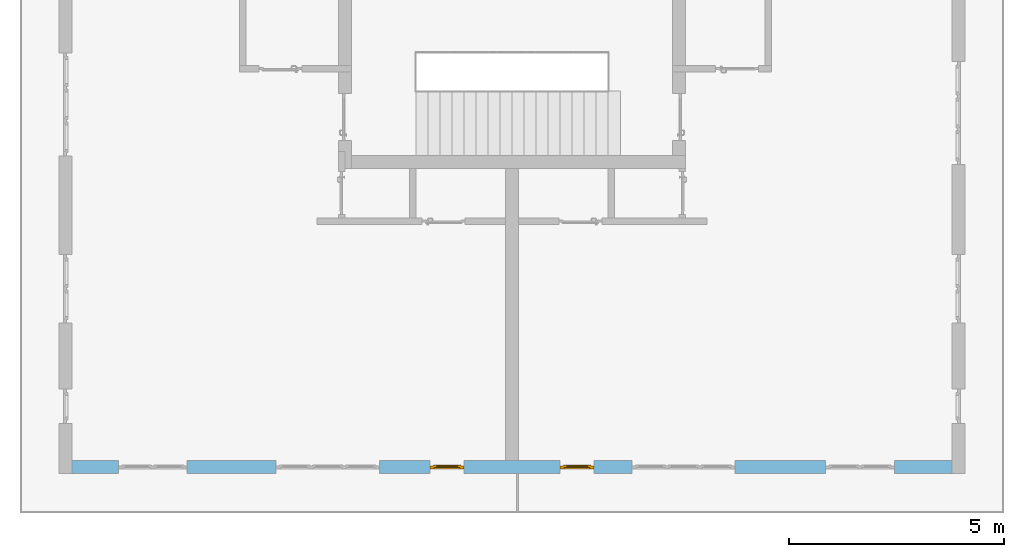
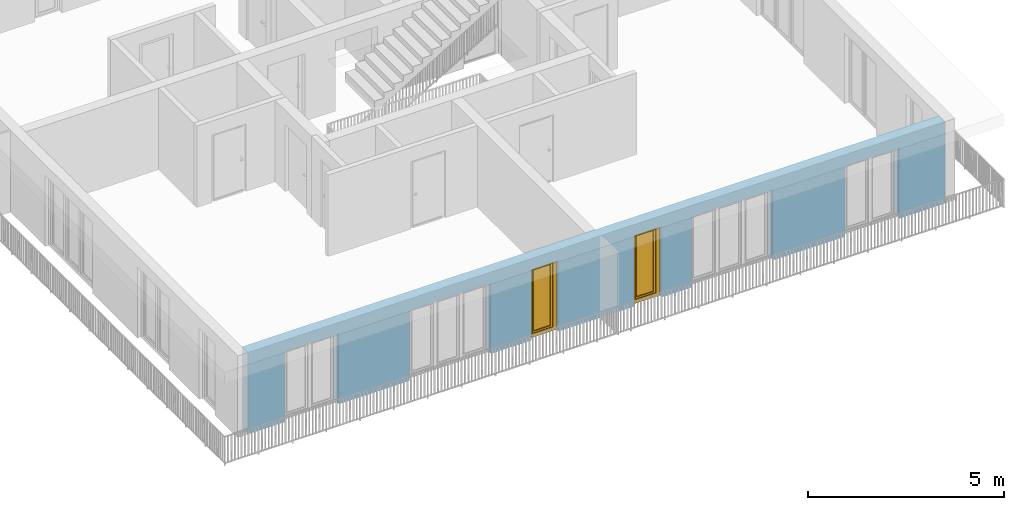
# One storey, part 6 of 48: 2 windows, 6 openings, plus 1 element that does not belong to this part.
"""IFC4 building model written with IfcOpenShell, lengths in metres."""

from ifc_helpers import new_model, entity, si_unit, converted_unit, derived_unit, direction, frame, origin_with_axes, place, context, subcontext, project, spatial, polygons, source, transform, mapped, material, type_object, element, fill, save


model = new_model("IFC4")

# Units and contexts
model_context = context("Model", 3, precision=1e-05, world=origin_with_axes(), true_north=direction((0.0, 1.0)))
body_context = subcontext(model_context, "Body", "Model", "MODEL_VIEW")
ifc_project = project(units=[si_unit("LENGTHUNIT", "METRE"), si_unit("AREAUNIT", "SQUARE_METRE"), si_unit("VOLUMEUNIT", "CUBIC_METRE"), converted_unit("PLANEANGLEUNIT", "DEGREE", entity("IfcPlaneAngleMeasure", 0.0174532925199), si_unit("PLANEANGLEUNIT", "RADIAN"), dimensions=[0, 0, 0, 0, 0, 0, 0]), converted_unit("TIMEUNIT", "Year", entity("IfcTimeMeasure", 31556926.0), si_unit("TIMEUNIT", "SECOND"), dimensions=[0, 0, 1, 0, 0, 0, 0]), si_unit("MASSUNIT", "GRAM", prefix="KILO"), si_unit("THERMODYNAMICTEMPERATUREUNIT", "DEGREE_CELSIUS"), si_unit("LUMINOUSINTENSITYUNIT", "LUMEN"), si_unit("ENERGYUNIT", "JOULE", prefix="MEGA"), derived_unit("THERMALCONDUCTANCEUNIT", [(si_unit("POWERUNIT", "WATT"), 1), (si_unit("LENGTHUNIT", "METRE"), -1), (si_unit("THERMODYNAMICTEMPERATUREUNIT", "KELVIN"), -1)]), derived_unit("SPECIFICHEATCAPACITYUNIT", [(si_unit("ENERGYUNIT", "JOULE"), 1), (si_unit("MASSUNIT", "GRAM", prefix="KILO"), -1), (si_unit("THERMODYNAMICTEMPERATUREUNIT", "KELVIN"), -1)]), derived_unit("MASSDENSITYUNIT", [(si_unit("MASSUNIT", "GRAM", prefix="KILO"), 1), (si_unit("VOLUMEUNIT", "CUBIC_METRE"), -1)])], contexts=[model_context])

# Site, building, storey
site_placement = place(None, origin_with_axes())
site = spatial("IfcSite", under=ifc_project, at=site_placement, CompositionType="ELEMENT")
building_placement = place(site_placement, origin_with_axes())
building = spatial("IfcBuilding", under=site, at=building_placement, CompositionType="ELEMENT")
storey_placement = place(building_placement, frame((0.0, 0.0, 3.4), z_axis=(0.0, 0.0, 1.0), x_axis=(1.0, 0.0, 0.0)))
storey = spatial("IfcBuildingStorey", under=building, at=storey_placement, Name="1. Geschoss", CompositionType="ELEMENT", Elevation=3.4)

# Wall, openings, windows
ifc_material = material()
wall_type = type_object("IfcWallType", Name="300", PredefinedType="NOTDEFINED")
wall_placement = place(storey_placement, frame((9.3378006196, -9.92881223104, 0.0), z_axis=(0.0, 0.0, 1.0), x_axis=(-1.0, 0.0, 0.0)))
wall = element("IfcWall", 1, at=wall_placement, inside=storey, type_object=wall_type, material=ifc_material, Name="Wand-001", PredefinedType="NOTDEFINED", context=body_context, shape_type="Tessellation", body=[
    polygons([(12.4515538751, -0.3, 2.2), (12.4515538751, -0.3, 0.0), (13.63, -0.3, 0.0), (13.63, -0.3, 2.2), (16.03, -0.3, 2.2), (16.03, -0.3, 0.0), (18.0998837323, -0.3, 0.0), (18.0998837323, -0.3, 2.2), (19.6998837323, -0.3, 2.2), (19.6998837323, -0.3, 0.0), (20.78, -0.3, 0.0), (20.78, -0.3, 2.54), (0.3, -0.3, 2.54), (0.3, -0.3, 0.0), (1.6378225413, -0.3, 0.0), (1.6378225413, -0.3, 2.2), (3.2378225413, -0.3, 2.2), (3.2378225413, -0.3, 0.0), (5.35, -0.3, 0.0), (5.35, -0.3, 2.2), (7.75, -0.3, 2.2), (7.75, -0.3, 0.0), (8.62617854928, -0.3, 0.0), (8.62617854928, -0.3, 2.2), (9.42617854928, -0.3, 2.2), (9.42617854928, -0.3, 0.0), (11.6515538751, -0.3, 0.0), (11.6515538751, -0.3, 2.2), (12.4515538751, -0.1, 0.0), (12.4515538751, 0.0, 2.2), (12.4515538751, 0.0, 0.0), (13.63, 0.0, 0.0), (13.63, 0.0, 2.2), (16.03, 0.0, 2.2), (16.03, 0.0, 0.0), (18.0998837323, 0.0, 0.0), (18.0998837323, 0.0, 2.2), (19.6998837323, 0.0, 2.2), (19.6998837323, 0.0, 0.0), (20.78, 0.0, 0.0), (20.78, 0.0, 2.54), (0.3, 0.0, 2.54), (0.3, 0.0, 0.0), (1.6378225413, 0.0, 0.0), (1.6378225413, 0.0, 2.2), (3.2378225413, 0.0, 2.2), (3.2378225413, 0.0, 0.0), (5.35, 0.0, 0.0), (5.35, 0.0, 2.2), (7.75, 0.0, 2.2), (7.75, 0.0, 0.0), (8.62617854928, 0.0, 0.0), (8.62617854928, 0.0, 2.2), (9.42617854928, 0.0, 2.2), (9.42617854928, 0.0, 0.0), (11.6515538751, -0.1, 0.0), (11.6515538751, 0.0, 0.0), (11.6515538751, 0.0, 2.2)], [[[1, 2, 3, 4, 5, 6, 7, 8, 9, 10, 11, 12, 13, 14, 15, 16, 17, 18, 19, 20, 21, 22, 23, 24, 25, 26, 27, 28]], [[29, 2, 1, 30, 31]], [[2, 29, 31, 32, 3]], [[32, 33, 4, 3]], [[33, 34, 5, 4]], [[34, 35, 6, 5]], [[36, 7, 6, 35]], [[36, 37, 8, 7]], [[37, 38, 9, 8]], [[38, 39, 10, 9]], [[40, 11, 10, 39]], [[40, 41, 12, 11]], [[41, 42, 13, 12]], [[14, 13, 42, 43]], [[15, 14, 43, 44]], [[16, 15, 44, 45]], [[17, 16, 45, 46]], [[18, 17, 46, 47]], [[19, 18, 47, 48]], [[20, 19, 48, 49]], [[21, 20, 49, 50]], [[22, 21, 50, 51]], [[51, 52, 23, 22]], [[52, 53, 24, 23]], [[53, 54, 25, 24]], [[54, 55, 26, 25]], [[56, 27, 26, 55, 57]], [[28, 27, 56, 57, 58]], [[1, 28, 58, 30]], [[32, 31, 30, 58, 57, 55, 54, 53, 52, 51, 50, 49, 48, 47, 46, 45, 44, 43, 42, 41, 40, 39, 38, 37, 36, 35, 34, 33]]], closed=True),
])
opening_1_placement = place(wall_placement, frame((18.8998837323, 0.0, 0.0), z_axis=(0.0, 0.0, 1.0), x_axis=(1.0, 0.0, 0.0)))
element("IfcOpeningElement", 2, at=opening_1_placement, cuts=wall, Name="Fenster-001", context=body_context, identifier="Reference", shape_type="Tessellation", body=[
    polygons([(-0.8, -0.1, 0.0), (-0.8, -0.1, 2.2), (-0.8, 0.001, 2.2), (-0.8, 0.001, 0.0), (-0.8, -0.301, 0.0), (-0.8, -0.301, 2.2), (0.8, -0.1, 2.2), (0.8, 0.001, 2.2), (0.8, -0.301, 2.2), (0.8, 0.001, 0.0), (0.8, -0.1, 0.0), (0.8, -0.301, 0.0)], [[[1, 2, 3, 4]], [[2, 1, 5, 6]], [[7, 8, 3, 2, 6, 9]], [[8, 10, 4, 3]], [[1, 4, 10, 11, 12, 5]], [[6, 5, 12, 9]], [[7, 11, 10, 8]], [[11, 7, 9, 12]]], closed=True),
])
opening_2_placement = place(wall_placement, frame((2.4378225413, 0.0, 0.0), z_axis=(0.0, 0.0, 1.0), x_axis=(1.0, 0.0, 0.0)))
element("IfcOpeningElement", 3, at=opening_2_placement, cuts=wall, Name="Fenster-002", context=body_context, identifier="Reference", shape_type="Tessellation", body=[
    polygons([(-0.8, -0.1, 0.0), (-0.8, -0.1, 2.2), (-0.8, 0.000999999999999, 2.2), (-0.8, 0.000999999999999, 0.0), (-0.8, -0.301, 0.0), (-0.8, -0.301, 2.2), (0.8, -0.1, 2.2), (0.8, 0.000999999999999, 2.2), (0.8, -0.301, 2.2), (0.8, 0.000999999999999, 0.0), (0.8, -0.1, 0.0), (0.8, -0.301, 0.0)], [[[1, 2, 3, 4]], [[2, 1, 5, 6]], [[7, 8, 3, 2, 6, 9]], [[8, 10, 4, 3]], [[1, 4, 10, 11, 12, 5]], [[6, 5, 12, 9]], [[7, 11, 10, 8]], [[11, 7, 9, 12]]], closed=True),
])
opening_3_placement = place(wall_placement, frame((14.83, 0.0, 0.0), z_axis=(0.0, 0.0, 1.0), x_axis=(1.0, 0.0, 0.0)))
element("IfcOpeningElement", 4, at=opening_3_placement, cuts=wall, Name="Fenster-002", context=body_context, identifier="Reference", shape_type="Tessellation", body=[
    polygons([(-1.2, -0.1, 0.0), (-1.2, -0.1, 2.2), (-1.2, 0.001, 2.2), (-1.2, 0.001, 0.0), (-1.2, -0.301, 0.0), (-1.2, -0.301, 2.2), (1.2, -0.1, 2.2), (1.2, 0.001, 2.2), (1.2, -0.301, 2.2), (1.2, 0.001, 0.0), (1.2, -0.1, 0.0), (1.2, -0.301, 0.0)], [[[1, 2, 3, 4]], [[2, 1, 5, 6]], [[7, 8, 3, 2, 6, 9]], [[8, 10, 4, 3]], [[1, 4, 10, 11, 12, 5]], [[6, 5, 12, 9]], [[7, 11, 10, 8]], [[11, 7, 9, 12]]], closed=True),
])
opening_4_placement = place(wall_placement, frame((6.55, 0.0, 0.0), z_axis=(0.0, 0.0, 1.0), x_axis=(1.0, 0.0, 0.0)))
element("IfcOpeningElement", 5, at=opening_4_placement, cuts=wall, Name="Fenster-003", context=body_context, identifier="Reference", shape_type="Tessellation", body=[
    polygons([(-1.2, -0.1, 0.0), (-1.2, -0.1, 2.2), (-1.2, 0.000999999999999, 2.2), (-1.2, 0.000999999999999, 0.0), (-1.2, -0.301, 0.0), (-1.2, -0.301, 2.2), (1.2, -0.1, 2.2), (1.2, 0.001, 2.2), (1.2, -0.301, 2.2), (1.2, 0.001, 0.0), (1.2, -0.1, 0.0), (1.2, -0.301, 0.0)], [[[1, 2, 3, 4]], [[2, 1, 5, 6]], [[7, 8, 3, 2, 6, 9]], [[8, 10, 4, 3]], [[1, 4, 10, 11, 12, 5]], [[6, 5, 12, 9]], [[7, 11, 10, 8]], [[11, 7, 9, 12]]], closed=True),
])
opening_5_placement = place(wall_placement, frame((9.02617854928, 0.0, 0.0), z_axis=(0.0, 0.0, 1.0), x_axis=(1.0, 0.0, 0.0)))
opening_5 = element("IfcOpeningElement", 6, at=opening_5_placement, cuts=wall, Name="Fenster-003", context=body_context, identifier="Reference", shape_type="Tessellation", body=[
    polygons([(-0.4, -0.1, 0.0), (-0.4, -0.1, 2.2), (-0.4, 0.001, 2.2), (-0.4, 0.001, 0.0), (-0.4, -0.301, 0.0), (-0.4, -0.301, 2.2), (0.4, -0.1, 2.2), (0.4, 0.001, 2.2), (0.4, -0.301, 2.2), (0.4, 0.001, 0.0), (0.4, -0.1, 0.0), (0.4, -0.301, 0.0)], [[[1, 2, 3, 4]], [[2, 1, 5, 6]], [[7, 8, 3, 2, 6, 9]], [[8, 10, 4, 3]], [[1, 4, 10, 11, 12, 5]], [[6, 5, 12, 9]], [[7, 11, 10, 8]], [[11, 7, 9, 12]]], closed=True),
])
opening_6_placement = place(wall_placement, frame((12.0515538751, 0.0, 0.0), z_axis=(0.0, 0.0, 1.0), x_axis=(1.0, 0.0, 0.0)))
opening_6 = element("IfcOpeningElement", 7, at=opening_6_placement, cuts=wall, Name="Fenster-003", context=body_context, identifier="Reference", shape_type="Tessellation", body=[
    polygons([(-0.4, -0.1, 0.0), (-0.4, -0.1, 2.2), (-0.4, 0.001, 2.2), (-0.4, 0.001, 0.0), (-0.4, -0.301, 0.0), (-0.4, -0.301, 2.2), (0.4, -0.1, 2.2), (0.4, 0.001, 2.2), (0.4, -0.301, 2.2), (0.4, 0.001, 0.0), (0.4, -0.1, 0.0), (0.4, -0.301, 0.0)], [[[1, 2, 3, 4]], [[2, 1, 5, 6]], [[7, 8, 3, 2, 6, 9]], [[8, 10, 4, 3]], [[1, 4, 10, 11, 12, 5]], [[6, 5, 12, 9]], [[7, 11, 10, 8]], [[11, 7, 9, 12]]], closed=True),
])
window_type = type_object("IfcWindowType", Name="1-26", PartitioningType="SINGLE_PANEL", PredefinedType="WINDOW")
shared_shape = source(origin_with_axes(), body_context, "Body", "Tessellation", [
    polygons([(-0.4, -0.07, 0.0), (-0.4, 0.0, 0.0), (-0.3, 0.0, 0.1), (-0.3, -0.07, 0.1), (-0.4, -0.07, 2.2), (-0.4, 0.0, 2.2), (-0.3, 0.0, 2.1), (-0.3, -0.07, 2.1)], [[[1, 2, 3, 4]], [[5, 6, 2, 1]], [[2, 6, 7, 3]], [[4, 3, 7, 8]], [[1, 4, 8, 5]], [[8, 7, 6, 5]]], closed=True),
    polygons([(0.4, -0.07, 0.0), (0.4, 0.0, 0.0), (0.4, 0.0, 2.2), (0.4, -0.07, 2.2), (0.3, -0.07, 0.1), (0.3, 0.0, 0.1), (0.3, 0.0, 2.1), (0.3, -0.07, 2.1)], [[[1, 2, 3, 4]], [[5, 6, 2, 1]], [[2, 6, 7, 3]], [[4, 3, 7, 8]], [[1, 4, 8, 5]], [[8, 7, 6, 5]]], closed=True),
    polygons([(-0.4, -0.07, 0.0), (-0.4, 0.0, 0.0), (0.4, 0.0, 0.0), (0.4, -0.07, 0.0), (-0.3, -0.07, 0.1), (-0.3, 0.0, 0.1), (0.0, 0.0, 0.1), (0.3, 0.0, 0.1), (0.3, -0.07, 0.1), (0.0, -0.07, 0.1)], [[[1, 2, 3, 4]], [[5, 6, 2, 1]], [[2, 6, 7, 8, 3]], [[4, 3, 8, 9]], [[1, 4, 9, 10, 5]], [[10, 7, 6, 5]], [[9, 8, 7, 10]]], closed=True),
    polygons([(-0.4, -0.07, 2.2), (-0.4, 0.0, 2.2), (-0.3, 0.0, 2.1), (-0.3, -0.07, 2.1), (0.4, -0.07, 2.2), (0.4, 0.0, 2.2), (0.3, 0.0, 2.1), (0.0, 0.0, 2.1), (0.0, -0.07, 2.1), (0.3, -0.07, 2.1)], [[[1, 2, 3, 4]], [[5, 6, 2, 1]], [[2, 6, 7, 8, 3]], [[4, 3, 8, 9]], [[1, 4, 9, 10, 5]], [[10, 7, 6, 5]], [[9, 8, 7, 10]]], closed=True),
    polygons([(-0.32, 0.0, 0.08), (-0.32, 0.03, 0.08), (-0.25, 0.03, 0.15), (-0.25, 0.0, 0.15), (-0.32, 0.0, 2.12), (-0.32, 0.03, 2.12), (-0.25, 0.03, 2.05), (-0.25, 0.0, 2.05)], [[[1, 2, 3, 4]], [[5, 6, 2, 1]], [[2, 6, 7, 3]], [[4, 3, 7, 8]], [[1, 4, 8, 5]], [[8, 7, 6, 5]]], closed=True),
    polygons([(0.32, 0.0, 0.08), (0.25, 0.0, 0.15), (0.25, 0.03, 0.15), (0.32, 0.03, 0.08), (0.32, 0.0, 2.12), (0.25, 0.0, 2.05), (0.25, 0.03, 2.05), (0.32, 0.03, 2.12)], [[[1, 2, 3, 4]], [[1, 5, 6, 2]], [[2, 6, 7, 3]], [[4, 3, 7, 8]], [[5, 1, 4, 8]], [[6, 5, 8, 7]]], closed=True),
    polygons([(-0.32, 0.0, 0.08), (-0.32, 0.03, 0.08), (0.32, 0.03, 0.08), (0.32, 0.0, 0.08), (-0.25, 0.0, 0.15), (-0.25, 0.03, 0.15), (0.25, 0.03, 0.15), (0.25, 0.0, 0.15)], [[[1, 2, 3, 4]], [[5, 6, 2, 1]], [[2, 6, 7, 3]], [[4, 3, 7, 8]], [[1, 4, 8, 5]], [[8, 7, 6, 5]]], closed=True),
    polygons([(-0.32, 0.0, 2.12), (0.32, 0.0, 2.12), (0.32, 0.03, 2.12), (-0.32, 0.03, 2.12), (-0.25, 0.0, 2.05), (0.25, 0.0, 2.05), (0.25, 0.03, 2.05), (-0.25, 0.03, 2.05)], [[[1, 2, 3, 4]], [[1, 5, 6, 2]], [[2, 6, 7, 3]], [[4, 3, 7, 8]], [[5, 1, 4, 8]], [[6, 5, 8, 7]]], closed=True),
    polygons([(-0.3, -0.03, 0.1), (-0.3, 0.0, 0.1), (-0.25, 0.0, 0.15), (-0.25, -0.03, 0.15), (-0.3, -0.03, 2.1), (-0.3, 0.0, 2.1), (-0.25, 0.0, 2.05), (-0.25, -0.03, 2.05)], [[[1, 2, 3, 4]], [[5, 6, 2, 1]], [[2, 6, 7, 3]], [[4, 3, 7, 8]], [[1, 4, 8, 5]], [[8, 7, 6, 5]]], closed=True),
    polygons([(0.3, -0.03, 0.1), (0.25, -0.03, 0.15), (0.25, 0.0, 0.15), (0.3, 0.0, 0.1), (0.3, -0.03, 2.1), (0.25, -0.03, 2.05), (0.25, 0.0, 2.05), (0.3, 0.0, 2.1)], [[[1, 2, 3, 4]], [[1, 5, 6, 2]], [[2, 6, 7, 3]], [[4, 3, 7, 8]], [[5, 1, 4, 8]], [[6, 5, 8, 7]]], closed=True),
    polygons([(-0.3, -0.03, 0.1), (-0.3, 0.0, 0.1), (0.3, 0.0, 0.1), (0.3, -0.03, 0.1), (-0.25, -0.03, 0.15), (-0.25, 0.0, 0.15), (0.25, 0.0, 0.15), (0.25, -0.03, 0.15)], [[[1, 2, 3, 4]], [[5, 6, 2, 1]], [[2, 6, 7, 3]], [[4, 3, 7, 8]], [[1, 4, 8, 5]], [[8, 7, 6, 5]]], closed=True),
    polygons([(-0.3, -0.03, 2.1), (0.3, -0.03, 2.1), (0.3, 0.0, 2.1), (-0.3, 0.0, 2.1), (-0.25, -0.03, 2.05), (0.25, -0.03, 2.05), (0.25, 0.0, 2.05), (-0.25, 0.0, 2.05)], [[[1, 2, 3, 4]], [[1, 5, 6, 2]], [[2, 6, 7, 3]], [[4, 3, 7, 8]], [[5, 1, 4, 8]], [[6, 5, 8, 7]]], closed=True),
    polygons([(-0.25, -0.005, 0.15), (-0.25, 0.005, 0.15), (0.25, 0.005, 0.15), (0.25, -0.005, 0.15), (-0.25, -0.005, 2.05), (-0.25, 0.005, 2.05), (0.25, 0.005, 2.05), (0.25, -0.005, 2.05)], [[[1, 2, 3, 4]], [[5, 6, 2, 1]], [[2, 6, 7, 3]], [[4, 3, 7, 8]], [[1, 4, 8, 5]], [[8, 7, 6, 5]]], closed=True),
])
window_1_placement = place(opening_5_placement, frame((0.4, 0.0, 0.0), z_axis=(0.0, 0.0, 1.0), x_axis=(-1.0, 0.0, 0.0)))
window_1 = element("IfcWindow", 8, at=window_1_placement, inside=storey, type_object=window_type, Name="Fenster-003", OverallHeight=2.2, OverallWidth=0.8, PredefinedType="WINDOW", context=body_context, shape_type="MappedRepresentation", body=[
    mapped(shared_shape, transform((0.4, 0.17, 0.0))),
])
fill(opening_5, window_1)
window_2_placement = place(opening_6_placement, frame((0.4, 0.0, 0.0), z_axis=(0.0, 0.0, 1.0), x_axis=(-1.0, 0.0, 0.0)))
window_2 = element("IfcWindow", 9, at=window_2_placement, inside=storey, type_object=window_type, Name="Fenster-003", OverallHeight=2.2, OverallWidth=0.8, PredefinedType="WINDOW", context=body_context, shape_type="MappedRepresentation", body=[
    mapped(shared_shape, transform((0.4, 0.17, 0.0))),
])
fill(opening_6, window_2)

save(model, "model.ifc")
